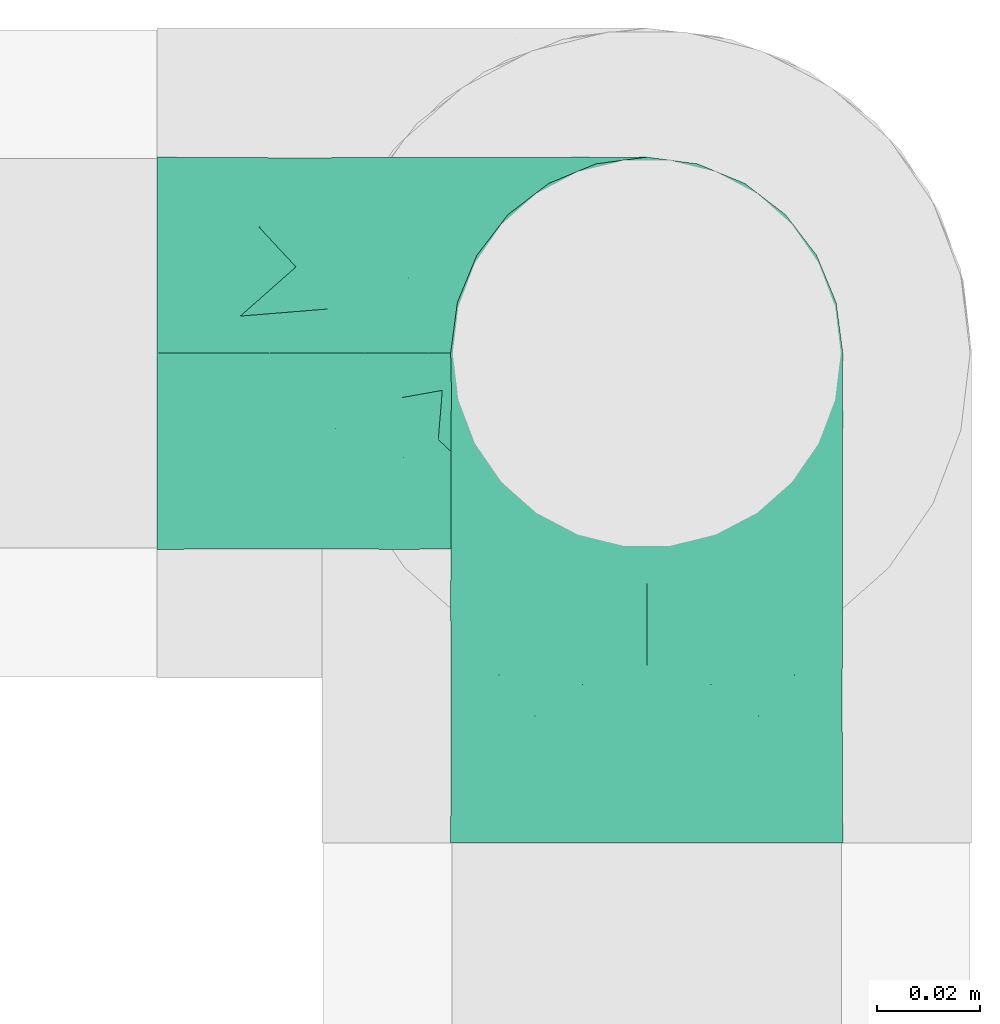
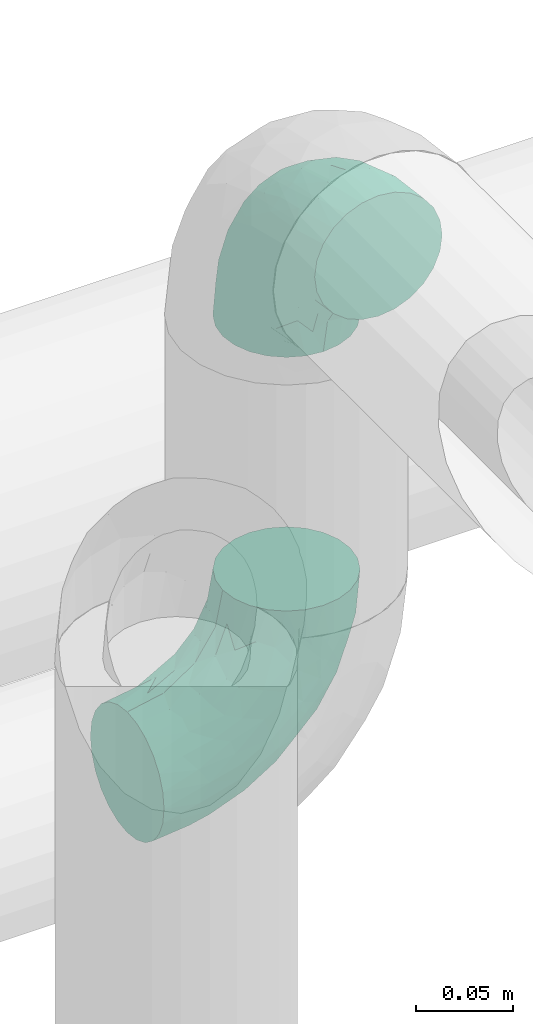
# One storey, part 561 of 827: 2 flow fittings.
"""IFC2X3 building model written with IfcOpenShell, lengths in millimetres."""

from ifc_helpers import new_model, entity, si_unit, converted_unit, derived_unit, direction, frame, origin, place, context, subcontext, project, spatial, faceted_brep, source, transform, mapped, material, type_object, type_shapes, element, save


model = new_model("IFC2X3")

# Units and contexts
model_context = context("Model", 3, precision=0.01, world=origin(), true_north=direction((6.12303176911189e-17, 1.0)))
body_context = subcontext(model_context, "Body", "Model", "MODEL_VIEW")
ifc_project = project(units=[si_unit("LENGTHUNIT", "METRE", prefix="MILLI"), si_unit("AREAUNIT", "SQUARE_METRE"), si_unit("VOLUMEUNIT", "CUBIC_METRE"), converted_unit("PLANEANGLEUNIT", "DEGREE", entity("IfcRatioMeasure", 0.0174532925199433), si_unit("PLANEANGLEUNIT", "RADIAN"), dimensions=[0, 0, 0, 0, 0, 0, 0]), si_unit("MASSUNIT", "GRAM", prefix="KILO"), derived_unit("MASSDENSITYUNIT", [(si_unit("MASSUNIT", "GRAM", prefix="KILO"), 1), (si_unit("LENGTHUNIT", "METRE"), -3)]), derived_unit("MOMENTOFINERTIAUNIT", [(si_unit("LENGTHUNIT", "METRE"), 4)]), si_unit("TIMEUNIT", "SECOND"), si_unit("FREQUENCYUNIT", "HERTZ"), si_unit("THERMODYNAMICTEMPERATUREUNIT", "DEGREE_CELSIUS"), derived_unit("THERMALTRANSMITTANCEUNIT", [(si_unit("MASSUNIT", "GRAM", prefix="KILO"), 1), (si_unit("THERMODYNAMICTEMPERATUREUNIT", "KELVIN"), -1), (si_unit("TIMEUNIT", "SECOND"), -3)]), derived_unit("VOLUMETRICFLOWRATEUNIT", [(si_unit("LENGTHUNIT", "METRE"), 3), (si_unit("TIMEUNIT", "SECOND"), -1)]), derived_unit("MASSFLOWRATEUNIT", [(si_unit("MASSUNIT", "GRAM", prefix="KILO"), 1), (si_unit("TIMEUNIT", "SECOND"), -1)]), derived_unit("ROTATIONALFREQUENCYUNIT", [(si_unit("TIMEUNIT", "SECOND"), -1)]), si_unit("ELECTRICCURRENTUNIT", "AMPERE"), si_unit("ELECTRICVOLTAGEUNIT", "VOLT"), si_unit("POWERUNIT", "WATT"), si_unit("FORCEUNIT", "NEWTON", prefix="KILO"), si_unit("ILLUMINANCEUNIT", "LUX"), si_unit("LUMINOUSFLUXUNIT", "LUMEN"), si_unit("LUMINOUSINTENSITYUNIT", "CANDELA"), derived_unit("USERDEFINED", [(si_unit("MASSUNIT", "GRAM", prefix="KILO"), -1), (si_unit("LENGTHUNIT", "METRE"), -2), (si_unit("TIMEUNIT", "SECOND"), 3), (si_unit("LUMINOUSFLUXUNIT", "LUMEN"), 1)]), derived_unit("LINEARVELOCITYUNIT", [(si_unit("LENGTHUNIT", "METRE"), 1), (si_unit("TIMEUNIT", "SECOND"), -1)]), si_unit("PRESSUREUNIT", "PASCAL"), derived_unit("USERDEFINED", [(si_unit("LENGTHUNIT", "METRE"), -2), (si_unit("MASSUNIT", "GRAM", prefix="KILO"), 1), (si_unit("TIMEUNIT", "SECOND"), -2)]), derived_unit("LINEARFORCEUNIT", [(si_unit("MASSUNIT", "GRAM", prefix="KILO"), 1), (si_unit("LENGTHUNIT", "METRE"), 1), (si_unit("TIMEUNIT", "SECOND"), -2), (si_unit("LENGTHUNIT", "METRE"), -1)]), derived_unit("PLANARFORCEUNIT", [(si_unit("MASSUNIT", "GRAM", prefix="KILO"), 1), (si_unit("LENGTHUNIT", "METRE"), 1), (si_unit("TIMEUNIT", "SECOND"), -2), (si_unit("LENGTHUNIT", "METRE"), -2)])], contexts=[model_context])

# Site, building, storey
site_placement = place(None, origin())
site = spatial("IfcSite", under=ifc_project, at=site_placement, CompositionType="ELEMENT")
building_placement = place(site_placement, origin())
building = spatial("IfcBuilding", under=site, at=building_placement, CompositionType="ELEMENT")
storey_placement = place(building_placement, frame((0.0, 0.0, 28200.0)))
storey = spatial("IfcBuildingStorey", under=building, at=storey_placement, Name="08", CompositionType="ELEMENT", Elevation=28200.0)

# Flow fittings
ifc_material = material()
pipe_fitting_type = type_object("IfcPipeFittingType", Name="ADSK_1", PredefinedType="NOTDEFINED", material=ifc_material)
shared_shape = source(origin(), body_context, "Body", "Brep", [
    faceted_brep([(-95.0, 19.02, -32.95), (-95.0, 9.85, -36.75), (-95.0, 0.0, -38.05), (-95.0, -9.85, -36.75), (-95.0, -19.03, -32.95), (-95.0, -26.91, -26.91), (-95.0, -32.95, -19.03), (-95.0, -36.75, -9.85), (-95.0, -38.05, 0.0), (-95.0, -36.75, 9.85), (-95.0, -32.95, 19.02), (-95.0, -26.91, 26.91), (-95.0, -19.03, 32.95), (-95.0, -9.85, 36.75), (-95.0, 0.0, 38.05), (-95.0, 9.85, 36.75), (-95.0, 19.02, 32.95), (-95.0, 26.91, 26.91), (-95.0, 32.95, 19.02), (-95.0, 36.75, 9.85), (-95.0, 38.05, 0.0), (-95.0, 36.75, -9.85), (-95.0, 32.95, -19.03), (-95.0, 26.91, -26.91), (0.0, 95.0, -38.05), (-9.85, 95.0, -36.75), (-19.02, 95.0, -32.95), (-26.91, 95.0, -26.91), (-32.95, 95.0, -19.03), (-36.75, 95.0, -9.85), (-38.05, 95.0, 0.0), (-36.75, 95.0, 9.85), (-32.95, 95.0, 19.02), (-26.91, 95.0, 26.91), (-19.02, 95.0, 32.95), (-9.85, 95.0, 36.75), (0.0, 95.0, 38.05), (9.85, 95.0, 36.75), (19.03, 95.0, 32.95), (26.91, 95.0, 26.91), (32.95, 95.0, 19.02), (36.75, 95.0, 9.85), (38.05, 95.0, 0.0), (36.75, 95.0, -9.85), (32.95, 95.0, -19.03), (26.91, 95.0, -26.91), (19.03, 95.0, -32.95), (9.85, 95.0, -36.75), (-7.99, -4.96, 6.3), (-0.92, 0.92, 0.0), (4.62, 8.1, 8.01), (-76.19, -35.57, 0.0), (-64.32, -32.32, 12.43), (20.51, 62.45, 28.68), (-60.56, -33.52, 0.0), (-70.4, -13.47, 34.42), (-39.61, -5.88, 32.32), (-49.6, 2.07, 37.1), (-70.34, -28.81, 21.71), (14.64, 40.81, 26.5), (5.88, 39.61, 32.32), (3.59, 20.77, 25.31), (-40.45, 68.06, 16.75), (-62.45, -20.51, 28.68), (-44.52, -26.87, 0.0), (-28.47, -20.22, 0.0), (-26.43, -17.83, 8.75), (-76.1, 39.63, 10.76), (-72.74, 37.58, 18.19), (-60.35, 46.18, 14.61), (-13.4, 13.4, 32.12), (-20.77, -3.59, 25.31), (-14.66, 81.47, 35.56), (-6.22, 71.26, 37.92), (-57.5, 42.48, 22.79), (-15.0, 34.74, 37.7), (-27.1, 12.08, 36.05), (-9.2, 28.81, 35.63), (-79.98, 23.7, 30.95), (-73.68, -4.3, 37.48), (-30.74, 21.67, 37.97), (-62.36, 47.59, 6.79), (-72.71, 32.83, 24.69), (-67.42, 7.02, 37.95), (-32.13, 75.27, 24.51), (-43.46, 51.47, 26.26), (-24.98, 73.15, 31.29), (20.59, 41.28, 19.85), (7.79, 16.09, 15.86), (-73.21, 42.39, 0.0), (-54.73, 54.73, 0.0), (-73.44, 15.79, 35.79), (-5.94, 4.32, 20.43), (28.81, 70.34, 21.71), (32.32, 64.32, 12.43), (-53.59, 26.2, 35.09), (-52.02, 19.31, 37.21), (21.38, 33.53, 10.34), (26.87, 44.52, 0.0), (-48.28, 12.14, 38.05), (4.3, 73.68, 37.48), (-44.08, -25.52, 12.79), (-41.28, -20.59, 19.85), (35.57, 76.19, 0.0), (-47.26, 54.3, 20.18), (-47.4, 61.99, 8.58), (-42.39, 73.21, 0.0), (-39.67, 78.86, 7.21), (-45.69, 36.84, 33.11), (-32.83, 50.13, 33.35), (13.47, 70.4, 34.42), (-18.25, 63.73, 36.07), (-40.63, -13.75, 27.22), (-16.63, 46.37, 37.95), (-53.47, 38.79, 28.59), (-26.07, 48.54, 36.15), (-34.51, 34.51, 36.86), (-2.07, 49.6, 37.1), (-22.79, -10.49, 19.23), (-61.73, 28.67, 31.87), (9.65, 14.7, 0.0), (20.22, 28.47, 0.0), (33.52, 60.56, 0.0), (-11.42, -5.44, 13.25), (-14.7, -9.65, 0.0), (-81.47, 14.66, -35.56), (-62.45, -20.51, -28.68), (-71.26, 6.22, -37.92), (-75.27, 32.13, -24.51), (-73.15, 24.98, -31.29), (13.47, 70.4, -34.42), (5.88, 39.61, -32.32), (-2.07, 49.6, -37.1), (-78.86, 39.67, -7.21), (-70.4, -13.47, -34.42), (-39.61, -5.88, -32.32), (-61.99, 47.4, -8.58), (32.32, 64.32, -12.43), (28.81, 70.34, -21.71), (-63.73, 18.25, -36.07), (-50.13, 32.83, -33.35), (4.3, 73.68, -37.48), (-7.02, 67.42, -37.95), (-39.63, 76.1, -10.76), (-46.18, 60.35, -14.61), (-47.59, 62.36, -6.79), (-64.32, -32.32, -12.43), (-26.2, 53.59, -35.09), (-15.79, 73.44, -35.79), (-19.31, 52.02, -37.21), (-37.58, 72.74, -18.19), (-70.34, -28.81, -21.71), (-42.48, 57.5, -22.79), (-38.79, 53.47, -28.59), (-51.47, 43.46, -26.26), (-32.83, 72.71, -24.69), (-46.37, 16.63, -37.95), (-73.68, -4.3, -37.48), (-41.28, -20.59, -19.85), (-44.08, -25.52, -12.79), (13.75, 40.63, -27.22), (20.51, 62.45, -28.68), (-68.06, 40.45, -16.75), (-54.3, 47.26, -20.18), (-12.14, 48.28, -38.05), (-21.67, 30.74, -37.97), (-36.84, 45.69, -33.11), (-11.42, -5.44, -13.25), (7.79, 16.09, -15.86), (4.62, 8.1, -8.01), (-23.7, 79.98, -30.95), (-26.43, -17.83, -8.75), (-7.99, -4.96, -6.3), (-40.81, -14.64, -26.5), (-20.77, -3.59, -25.31), (-34.74, 15.0, -37.7), (-12.08, 27.1, -36.05), (-28.81, 9.2, -35.63), (-22.79, -10.49, -19.23), (21.38, 33.53, -10.34), (20.59, 41.28, -19.85), (-48.54, 26.07, -36.15), (-49.6, 2.07, -37.1), (-13.4, 13.4, -32.12), (3.59, 20.77, -25.31), (-28.67, 61.73, -31.87), (-34.51, 34.51, -36.86), (-5.94, 4.32, -20.43)], [[[0, 1, 2, 3, 4, 5, 6, 7, 8, 9, 10, 11, 12, 13, 14, 15, 16, 17, 18, 19, 20, 21, 22, 23]], [[24, 25, 26, 27, 28, 29, 30, 31, 32, 33, 34, 35, 36, 37, 38, 39, 40, 41, 42, 43, 44, 45, 46, 47]], [[48, 49, 50]], [[51, 52, 9]], [[53, 39, 38]], [[9, 52, 10]], [[54, 52, 51]], [[55, 56, 57]], [[11, 10, 58]], [[59, 60, 61]], [[32, 31, 62]], [[63, 12, 11]], [[63, 55, 12]], [[64, 65, 66]], [[67, 68, 69]], [[70, 56, 71]], [[35, 72, 73]], [[69, 68, 74]], [[75, 76, 77]], [[16, 78, 17]], [[13, 79, 14]], [[76, 75, 80]], [[67, 69, 81]], [[18, 17, 82]], [[14, 79, 83]], [[20, 19, 67]], [[84, 85, 86]], [[87, 61, 88]], [[89, 81, 90]], [[18, 82, 68]], [[15, 91, 16]], [[14, 83, 15]], [[71, 92, 61]], [[17, 78, 82]], [[93, 87, 94]], [[95, 91, 96]], [[97, 98, 94]], [[86, 72, 34]], [[96, 99, 80]], [[37, 36, 100]], [[40, 39, 93]], [[40, 94, 41]], [[64, 66, 101]], [[93, 94, 40]], [[58, 102, 63]], [[94, 103, 41]], [[94, 87, 97]], [[104, 69, 74]], [[34, 33, 86]], [[105, 69, 104]], [[52, 58, 10]], [[106, 107, 30]], [[108, 109, 85]], [[105, 106, 90]], [[53, 110, 60]], [[86, 111, 72]], [[86, 109, 111]], [[33, 84, 86]], [[12, 55, 13]], [[112, 56, 63]], [[110, 38, 37]], [[34, 72, 35]], [[36, 35, 73]], [[111, 113, 73]], [[105, 107, 106]], [[110, 53, 38]], [[74, 114, 85]], [[91, 15, 83]], [[105, 90, 81]], [[107, 62, 31]], [[33, 32, 84]], [[115, 109, 116]], [[111, 115, 113]], [[100, 73, 117]], [[56, 55, 63]], [[79, 55, 57]], [[102, 118, 112]], [[56, 70, 76]], [[100, 110, 37]], [[117, 77, 60]], [[117, 60, 110]], [[60, 70, 61]], [[58, 52, 101]], [[63, 11, 58]], [[39, 53, 93]], [[87, 93, 53]], [[96, 91, 83]], [[78, 91, 119]], [[32, 62, 84]], [[84, 62, 104]], [[86, 85, 109]], [[85, 114, 108]], [[80, 113, 116]], [[117, 73, 113]], [[80, 116, 96]], [[80, 57, 76]], [[71, 112, 118]], [[61, 87, 59]], [[62, 107, 105]], [[97, 120, 121]], [[70, 71, 61]], [[71, 118, 92]], [[73, 100, 36]], [[110, 100, 117]], [[55, 79, 13]], [[83, 79, 57]], [[96, 83, 99]], [[116, 108, 95]], [[50, 97, 88]], [[97, 87, 88]], [[50, 49, 120]], [[122, 94, 98]], [[89, 20, 67]], [[105, 81, 69]], [[89, 67, 81]], [[68, 19, 18]], [[68, 67, 19]], [[74, 68, 82]], [[114, 82, 119]], [[74, 85, 104]], [[82, 114, 74]], [[114, 119, 108]], [[95, 108, 119]], [[116, 109, 108]], [[123, 48, 50]], [[97, 50, 120]], [[123, 50, 88]], [[91, 95, 119]], [[116, 95, 96]], [[84, 104, 85]], [[104, 62, 105]], [[83, 57, 99]], [[57, 80, 99]], [[66, 48, 123]], [[66, 124, 48]], [[118, 66, 123]], [[124, 66, 65]], [[66, 118, 101]], [[54, 64, 52]], [[124, 49, 48]], [[30, 107, 31]], [[91, 78, 16]], [[82, 78, 119]], [[56, 76, 57]], [[77, 76, 70]], [[60, 77, 70]], [[77, 117, 75]], [[117, 113, 75]], [[113, 80, 75]], [[9, 8, 51]], [[103, 94, 122]], [[103, 42, 41]], [[73, 72, 111]], [[113, 115, 116]], [[111, 109, 115]], [[102, 112, 63]], [[71, 56, 112]], [[118, 102, 101]], [[92, 123, 88]], [[123, 92, 118]], [[61, 92, 88]], [[87, 53, 59]], [[60, 59, 53]], [[97, 121, 98]], [[58, 101, 102]], [[64, 101, 52]], [[125, 1, 0]], [[126, 5, 4]], [[2, 1, 127]], [[1, 125, 127]], [[128, 129, 23]], [[130, 131, 132]], [[89, 133, 20]], [[126, 134, 135]], [[136, 89, 90]], [[137, 138, 44]], [[139, 129, 140]], [[24, 141, 142]], [[143, 144, 145]], [[125, 129, 139]], [[6, 146, 7]], [[147, 148, 149]], [[146, 51, 7]], [[143, 150, 144]], [[146, 6, 151]], [[152, 153, 154]], [[126, 4, 134]], [[0, 23, 129]], [[28, 155, 150]], [[43, 42, 103]], [[54, 146, 64]], [[139, 156, 127]], [[157, 3, 2]], [[151, 158, 159]], [[160, 131, 161]], [[22, 21, 162]], [[136, 144, 163]], [[149, 164, 165]], [[24, 142, 25]], [[166, 140, 154]], [[154, 129, 128]], [[143, 30, 29]], [[167, 168, 169]], [[155, 28, 27]], [[26, 170, 27]], [[171, 167, 172]], [[26, 25, 148]], [[27, 170, 155]], [[173, 135, 174]], [[144, 150, 152]], [[175, 176, 177]], [[24, 47, 141]], [[45, 161, 46]], [[148, 25, 142]], [[176, 175, 165]], [[64, 159, 171]], [[138, 45, 44]], [[130, 46, 161]], [[137, 44, 43]], [[178, 159, 158]], [[137, 103, 122]], [[163, 144, 152]], [[136, 133, 89]], [[103, 137, 43]], [[6, 5, 151]], [[178, 158, 173]], [[134, 4, 3]], [[178, 173, 174]], [[137, 98, 179]], [[145, 90, 106]], [[138, 180, 161]], [[46, 130, 47]], [[136, 90, 145]], [[133, 162, 21]], [[23, 22, 128]], [[139, 140, 181]], [[139, 181, 156]], [[157, 127, 182]], [[157, 134, 3]], [[182, 177, 135]], [[182, 135, 134]], [[135, 183, 174]], [[131, 130, 161]], [[141, 130, 132]], [[160, 180, 184]], [[131, 183, 176]], [[5, 126, 151]], [[158, 151, 126]], [[180, 138, 137]], [[161, 45, 138]], [[149, 148, 142]], [[170, 148, 185]], [[22, 162, 128]], [[128, 162, 163]], [[129, 154, 140]], [[154, 153, 166]], [[165, 156, 186]], [[182, 127, 156]], [[165, 186, 149]], [[165, 132, 176]], [[131, 184, 183]], [[187, 167, 178]], [[184, 168, 187]], [[167, 169, 172]], [[184, 180, 168]], [[174, 183, 184]], [[127, 157, 2]], [[134, 157, 182]], [[130, 141, 47]], [[142, 141, 132]], [[149, 142, 164]], [[186, 166, 147]], [[180, 179, 168]], [[169, 179, 120]], [[137, 179, 180]], [[179, 121, 120]], [[106, 30, 143]], [[136, 145, 144]], [[106, 143, 145]], [[150, 29, 28]], [[150, 143, 29]], [[152, 150, 155]], [[153, 155, 185]], [[152, 154, 163]], [[155, 153, 152]], [[153, 185, 166]], [[147, 166, 185]], [[186, 140, 166]], [[169, 120, 49]], [[169, 49, 172]], [[179, 169, 168]], [[148, 147, 185]], [[186, 147, 149]], [[128, 163, 154]], [[163, 162, 136]], [[142, 132, 164]], [[132, 165, 164]], [[171, 124, 65]], [[124, 171, 172]], [[64, 146, 159]], [[171, 159, 178]], [[171, 65, 64]], [[172, 49, 124]], [[162, 133, 136]], [[20, 133, 21]], [[148, 170, 26]], [[155, 170, 185]], [[131, 176, 132]], [[177, 176, 183]], [[135, 177, 183]], [[177, 182, 175]], [[182, 156, 175]], [[156, 165, 175]], [[51, 146, 54]], [[51, 8, 7]], [[129, 125, 0]], [[127, 125, 139]], [[140, 186, 181]], [[156, 181, 186]], [[158, 126, 173]], [[135, 173, 126]], [[187, 178, 174]], [[171, 178, 167]], [[184, 187, 174]], [[167, 187, 168]], [[180, 160, 161]], [[184, 131, 160]], [[98, 137, 122]], [[98, 121, 179]], [[151, 159, 146]]]),
])
type_shapes(pipe_fitting_type, [shared_shape])
for number, where, z_axis, x_axis, name in (
    (1, (26867.64, 12070.0, 3100.0), (0.0, -1.0, 0.0), (1.0, 0.0, 0.0), "ADSK_1"),
    (2, (26867.64, 12070.0, 3450.0), (1.0, 0.0, 0.0), (0.0, 0.0, 1.0), "ADSK_1"),
):
    element("IfcFlowFitting", number, at=place(storey_placement, frame(where, z_axis=z_axis, x_axis=x_axis)), inside=storey, type_object=pipe_fitting_type, material=ifc_material, Name=name, ObjectType="ADSK_1", context=body_context, shape_type="MappedRepresentation", body=[
        mapped(shared_shape, transform((0.0, 0.0, 0.0), scale=1.0)),
    ])

save(model, "model.ifc")
